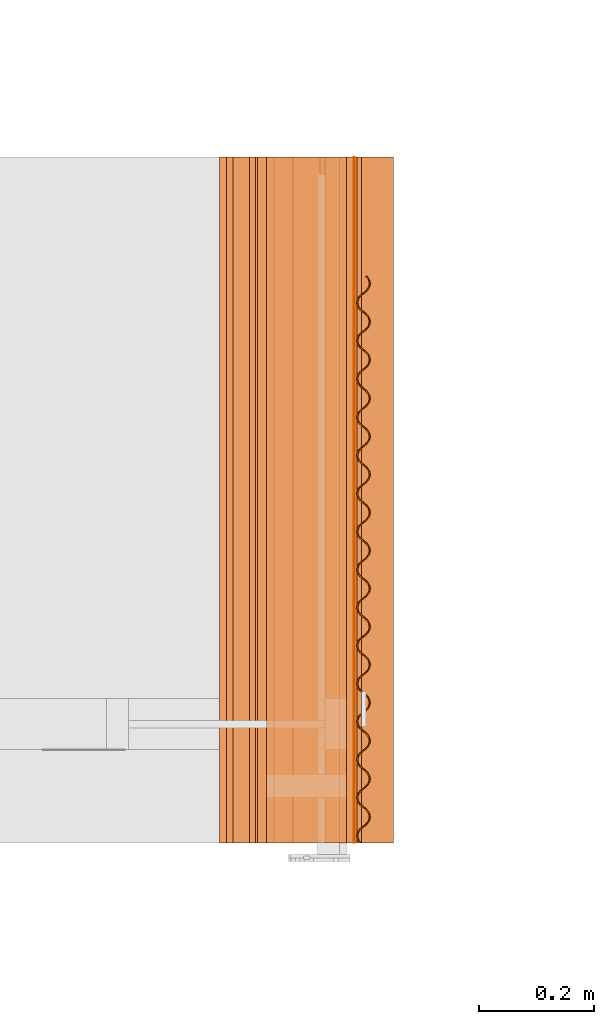
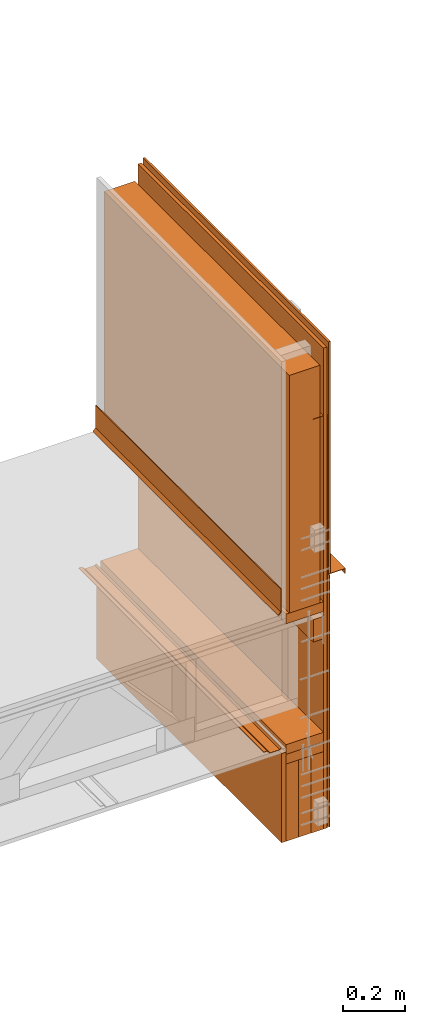
# One storey, part 2 of 22: 17 proxies.
"""IFC2X3 building model written with IfcOpenShell, lengths in feet."""

from ifc_helpers import new_model, entity, si_unit, converted_unit, frame, frame_2d, origin_with_axes, place, context, subcontext, project, spatial, polyline, rectangle, outline, extrude, shape, element, save


model = new_model("IFC2X3")

# Units and contexts
model_context = context("Model", 3, precision=1e-05)
plan_context = context("Plan", 2, precision=1e-05, world=frame_2d((0.0, 0.0, 0.0), x_axis=(1.0, 0.0, 0.0)))
body_context_1 = subcontext(model_context, "Body", "Model", "MODEL_VIEW")
body_context_2 = subcontext(model_context, "Body", "Model", "MODEL_VIEW")
ifc_project = project(units=[converted_unit("VOLUMEUNIT", "cubic foot", entity("IfcReal", 0.0283168467116885), si_unit("VOLUMEUNIT", "CUBIC_METRE"), dimensions=[3, 0, 0, 0, 0, 0, 0]), converted_unit("AREAUNIT", "square foot", entity("IfcReal", 0.09290304), si_unit("AREAUNIT", "SQUARE_METRE"), dimensions=[2, 0, 0, 0, 0, 0, 0]), converted_unit("LENGTHUNIT", "foot", entity("IfcReal", 0.3048), si_unit("LENGTHUNIT", "METRE"), dimensions=[1, 0, 0, 0, 0, 0, 0])], contexts=[model_context, plan_context])

# Site, building, storey
site_placement = place(None, origin_with_axes())
site = spatial("IfcSite", under=ifc_project, at=site_placement, CompositionType="ELEMENT")
building_placement = place(site_placement, origin_with_axes())
building = spatial("IfcBuilding", under=site, at=building_placement, Name="Building", CompositionType="ELEMENT")
storey_placement = place(building_placement, origin_with_axes())
storey = spatial("IfcBuildingStorey", under=building, at=storey_placement, Name="Storey", CompositionType="ELEMENT")

# Proxies
proxy_1_placement = place(storey_placement, frame((1595.46769510104, 0.875491228472842, -57.9246385829655), z_axis=(0.0, 0.0, 1.0), x_axis=(1.0, 0.0, 0.0)))
element("IfcBuildingElementProxy", 1, at=proxy_1_placement, inside=storey, Name="Plane", context=body_context_1, shape_type="SweptSolid", body=[
    extrude(rectangle(XDim=0.375023212116717, YDim=3.92583333372057, at=frame_2d((0.0, 0.0, 0.0))), frame((0.27084493339844, 2.97847343242075, -2.03039878465998), z_axis=(0.0, 0.0, -1.0), x_axis=(0.999999940395355, 0.0, 0.0)), (0.0, 0.0, -1.0), 3.07234290048816),
])
proxy_2_placement = place(storey_placement, frame((1595.45728227911, 1.8910506344217, -63.2148777718932), z_axis=(0.0, 0.0, 1.0), x_axis=(-1.62920684942947e-07, 1.0, 0.0)))
element("IfcBuildingElementProxy", 2, at=proxy_2_placement, inside=storey, Name="Generic Models 845:Generic Models 1", context=body_context_1, shape_type="SweptSolid", body=[
    extrude(rectangle(XDim=3.92583333372057, YDim=0.0520833335148361, at=frame_2d((0.0, 0.0, 0.0))), frame((1.96291666644139, -0.0260416674977682, 0.322346925109703), z_axis=(0.0, 0.0, -1.0), x_axis=(1.0, 0.0, 0.0)), (0.0, 0.0, -1.0), 1.15625032746861),
])
proxy_3_placement = place(storey_placement, frame((1593.45731960507, 1.8910506344217, -61.6841992055337), z_axis=(0.0, 0.0, 1.0), x_axis=(-1.62920684942947e-07, 1.0, 0.0)))
element("IfcBuildingElementProxy", 3, at=proxy_3_placement, inside=storey, Name="Dowel60:Dowel", context=body_context_1, shape_type="SweptSolid", body=[
    extrude(outline(polyline([(0.0667669798132629, 0.015256727502982), (0.106276372286278, 0.015256727502982), (0.106276372286278, 0.0204650634469518), (0.064609629735155, 0.0204650573359113), (0.0281512659052851, -0.0159932851053168), (-0.0894830373954272, -0.0159932973273978), (-0.108790796572768, 0.00331454740450999), (-0.112473651805888, -0.000368289853557101), (-0.0916403813624945, -0.0212016363268879), (0.0303086098723524, -0.0212016149382461), (0.0667669798132629, 0.015256727502982)])), frame((3.92583372398937, -1.88752637291205, 0.0212016454934487), z_axis=(1.0, -1.85782892003772e-06, 0.0), x_axis=(0.0, 0.999999940395355, -7.73365513850877e-08)), (-4.17659351548139e-10, -4.49406556413123e-09, -1.0), 3.92583333372057),
])
proxy_4_placement = place(storey_placement, frame((1595.50934638877, 1.8910506344217, -60.080036403626), z_axis=(0.0, 0.0, 1.0), x_axis=(-1.62920684942947e-07, 1.0, 0.0)))
element("IfcBuildingElementProxy", 4, at=proxy_4_placement, inside=storey, Name="Generic Models 857:Generic Models 1", context=body_context_1, shape_type="SweptSolid", body=[
    extrude(rectangle(XDim=0.458387200127976, YDim=3.92583333372057, at=frame_2d((0.0, 0.0, 0.0))), frame((1.96291666644139, -0.229193596780457, 0.0), z_axis=(0.0, 0.0, -1.0), x_axis=(-6.35700810364842e-15, 0.999999940395355, 0.0)), (-9.98035137064583e-14, -1.16558848618949e-14, -1.0), 0.125000000235113),
])
proxy_5_placement = place(storey_placement, frame((1595.2593385391, 0.875491228472842, -61.4761492711665), z_axis=(0.0, 0.0, 1.0), x_axis=(1.0, 0.0, 0.0)))
element("IfcBuildingElementProxy", 5, at=proxy_5_placement, inside=storey, Name="Plane", context=body_context_1, shape_type="SweptSolid", body=[
    extrude(rectangle(XDim=3.92583333372057, YDim=0.0416667373353818, at=frame_2d((0.0, 0.0, 0.0))), frame((0.729220980421452, 2.97847343242075, -1.41638314004332), z_axis=(0.0, 0.0, -1.0), x_axis=(0.0, -1.0, 0.0)), (0.0, 1.57243427167941e-08, -1.0), 6.21817093705122),
])
proxy_6_placement = place(storey_placement, frame((1595.96771080037, 1.8910506344217, -61.6425354023931), z_axis=(0.0, 0.0, 1.0), x_axis=(1.0, 0.0, 0.0)))
element("IfcBuildingElementProxy", 6, at=proxy_6_placement, inside=storey, Name="Generic Models 857:Generic Models 1", context=body_context_1, shape_type="SweptSolid", body=[
    extrude(rectangle(XDim=3.92583333372062, YDim=0.458337028879998, at=frame_2d((0.0, 0.0, 0.0))), frame((-0.22916851707018, 1.96291666644139, -0.124999744881169), z_axis=(2.39995301853924e-07, 1.5877549230936e-07, -1.0), x_axis=(0.0, -1.0, -1.5877549230936e-07)), (-3.26364776133056e-13, -1.95553198523157e-07, -1.0), 0.125000000235115),
])
proxy_7_placement = place(storey_placement, frame((1595.96771080037, 1.8910506344217, -61.7675330695205), z_axis=(0.0, 0.0, 1.0), x_axis=(1.0, 0.0, 0.0)))
element("IfcBuildingElementProxy", 7, at=proxy_7_placement, inside=storey, Name="Generic Models 857:Generic Models 1", context=body_context_1, shape_type="SweptSolid", body=[
    extrude(rectangle(XDim=3.92583333372062, YDim=0.458337028879998, at=frame_2d((0.0, 0.0, 0.0))), frame((-0.22916851707018, 1.96291666644139, -0.124999744881169), z_axis=(2.39995301853924e-07, 1.5877549230936e-07, -1.0), x_axis=(0.0, -1.0, -1.5877549230936e-07)), (-3.58418373105907e-13, -1.95553198523157e-07, -1.0), 0.125000025296795),
])
for number, where, z_axis, x_axis, name in (
    (8, (1595.83004127963, 1.891050829975, -62.7675331796561), (0.0, 0.0, 1.0), (1.0, 0.0, 0.0), "Generic Models 857:Generic Models 1"),
    (9, (1596.13591792389, 1.891050829975, -62.7675331796561), (0.0, 0.0, 1.0), (1.0, 0.0, 0.0), "Generic Models 857:Generic Models 1"),
    (10, (1595.98252904697, 1.891050829975, -62.7675331796561), (0.0, 0.0, 1.0), (1.0, 0.0, 0.0), "Generic Models 857:Generic Models 1"),
):
    element("IfcBuildingElementProxy", number, at=place(storey_placement, frame(where, z_axis=z_axis, x_axis=x_axis)), inside=storey, Name=name, context=body_context_1, shape_type="SweptSolid", body=[
        extrude(rectangle(XDim=3.92583333372062, YDim=0.152474618603812, at=frame_2d((0.0, 0.0, 0.0))), frame((-0.244431207420945, 1.96291666644139, -0.124999744881169), z_axis=(3.20632494776874e-07, 1.61888749516947e-07, -1.0), x_axis=(0.0, -1.0, -1.61888735306093e-07)), (5.39006101973882e-08, -2.80553450693333e-07, -1.0), 1.00000000188095),
    ])
proxy_8_placement = place(storey_placement, frame((1596.15273863625, 5.81679851051391, -59.6816208106013), z_axis=(0.0, 0.0, 1.0), x_axis=(1.0, 0.0, 0.0)))
element("IfcBuildingElementProxy", 11, at=proxy_8_placement, inside=storey, Name="Vert", shapes=[
    shape(model_context, None, "SweptSolid", [extrude(outline(polyline([(-0.111276951185831, -0.0128149069611012), (0.106073632406125, -0.0128149069611012), (0.105995484420008, -0.0752837169827439), (0.111236618318426, -0.0752902741292174), (0.111321329562057, -0.00757376236836194), (-0.106035853953656, -0.00757376236836194), (-0.106036562834355, 0.0956756847463255), (-0.111277696732774, 0.0956756480800824), (-0.111276951185831, -0.0128149069611012)])), frame((-0.026900244246083, -3.92574963607187, 0.0727010201516114), z_axis=(2.51794244832126e-06, -1.0, 2.70907967205858e-05), x_axis=(1.0, 1.7994273093791e-06, -6.80408447806258e-06)), (-5.10877271153731e-06, 3.48751855199225e-05, -1.0), 3.92582941395886)]),
])
proxy_9_placement = place(storey_placement, frame((1596.0439046224, 1.89104476782281, -59.6308019843314), z_axis=(3.25841057247089e-07, -8.02678641775856e-07, 1.0), x_axis=(1.0, -3.89414367418794e-07, -3.25841369885893e-07)))
element("IfcBuildingElementProxy", 12, at=proxy_9_placement, inside=storey, Name="Generic Models 1:Generic Models 1", context=body_context_2, shape_type="SweptSolid", body=[
    extrude(outline(polyline([(1.16708250887438, -2.11260580333082e-09), (1.15589578477104, 0.00647791606933856), (1.14346416838213, 0.00988080925882606), (1.1305774016956, 0.0101899866594046), (1.11800968021233, 0.0073867912643792), (1.10649990206315, 0.00145350277498413), (1.09679107199817, -0.00692655810880966), (1.06670949950306, -0.0407574166668447), (1.05699421617928, -0.0491374162492633), (1.04550585111608, -0.054971070525058), (1.03292356091221, -0.0578740714337882), (1.02003014541361, -0.0575647305628759), (1.00761974655737, -0.0540620165820823), (0.996406133875759, -0.0476837860972784), (0.987127912169679, -0.0388481015011942), (0.958679209700407, -0.00361300069286324), (0.94937673938556, 0.00522326292430987), (0.938190406388811, 0.0117010804531201), (0.925758789999904, 0.0151039682954472), (0.912865178947999, 0.0154134023597273), (0.900291786419125, 0.0126102459225853), (0.888800781386418, 0.00667651190014258), (0.879091560214836, -0.00170363854858878), (0.848997863415345, -0.035534108673611), (0.83927593127949, -0.0439139279803344), (0.827800277180559, -0.0497479000302359), (0.815211338164612, -0.0526507267743114), (0.802317922666004, -0.0523413859033991), (0.789902048317466, -0.0488386444229232), (0.778699973280348, -0.0424606033803753), (0.769410213929774, -0.0336246468429881), (0.740960875912288, 0.00161039285493765), (0.731671165450039, 0.0104463402257641), (0.720471877047396, 0.0169245725414493), (0.708046762805598, 0.0203272992050828), (0.695147285154798, 0.0206367668800858), (0.682579710336495, 0.0178336784282694), (0.67108269203992, 0.0118999887108705), (0.661373421980014, 0.00351994444146811), (0.631292289479824, -0.0303109259567079), (0.621570552897266, -0.0386907697075934), (0.610081992280765, -0.0445244270389083), (0.597499897630196, -0.0474274187810778), (0.584612739837076, -0.0471182306861784), (0.572196278828648, -0.0436154647615403), (0.560988532745932, -0.0372372862205809), (0.551698382288765, -0.0284013174611127), (0.52325569308336, 0.00683355647483914), (0.513953076103541, 0.0156698231475325), (0.502760045406387, 0.0221477965078759), (0.490335126717885, 0.0255506087260766), (0.477447968924765, 0.025859796820976), (0.46487433195427, 0.0230567450354027), (0.453377118104399, 0.0171231553862922), (0.44366804359779, 0.00874301677770189), (0.413580457838814, -0.0250876087969135), (0.403858916809553, -0.0334674525477989), (0.392376589454378, -0.0393012626551268), (0.379787845991728, -0.0422040832881618), (0.366894626046416, -0.041894760750371), (0.354484422743477, -0.0383921445462256), (0.343276505551626, -0.0320139660052662), (0.333986379538621, -0.0231780033568385), (0.305537432627728, 0.012057127242815), (0.296247379947209, 0.0208930043366755), (0.285048213765377, 0.0273711060288697), (0.272623099523579, 0.0307740358846003), (0.259729781801619, 0.0310832606457428), (0.247162304759964, 0.0282800652507174), (0.235658808760443, 0.0223466283776198), (0.225955943070997, 0.0139663339374963), (0.195874810570807, -0.0198644474686522), (0.186152951767438, -0.0282442728864161), (0.174658402331232, -0.0340777835527586), (0.162076026572799, -0.0369807752949281), (0.149188771003031, -0.0366715780334679), (0.136772493325819, -0.0331688212753907), (0.125570833839457, -0.0267906946782756), (0.116280903379748, -0.0179548359175367), (0.0878317486934774, 0.0172802014887489), (0.0785293028227926, 0.0261164635781619), (0.0673424564986404, 0.0325943926334616), (0.0549176233647064, 0.0359971024917336), (0.042024207866098, 0.0363064403071256), (0.0294504853410358, 0.0335033885215524), (0.0179470855904024, 0.0275699470651744), (0.00824273186259148, 0.0191896923468143), (-0.0218447484809348, -0.014640931700041), (-0.0315665033966146, -0.0230206685077174), (-0.0430486321429724, -0.0288545794472137), (-0.0556371739412856, -0.0317573175812018), (-0.0685307849931905, -0.0314479736547692), (-0.0809407010772253, -0.0279453696727049), (-0.0921424644512767, -0.0215673408522381), (-0.101432492687633, -0.0127313728566499), (-0.129887611749448, 0.0225037019797589), (-0.139183897691292, 0.0313398204597197), (-0.150370939568741, 0.0378177495150194), (-0.162801932631515, 0.041220609093784), (-0.175689188201284, 0.0415298063552442), (-0.188256653020858, 0.0387265987381378), (-0.199766308949219, 0.0327933039467322), (-0.209475542342882, 0.0244132631147901), (-0.239556577066424, -0.00941761224860633), (-0.249272080387656, -0.0177975957895436), (-0.260760469895022, -0.0236312500653383), (-0.273342955652184, -0.0265342479185482), (-0.286236371150793, -0.0262249039921157), (-0.298646281123787, -0.0227222098722037), (-0.309860358244478, -0.016343968693079), (-0.319137968846506, -0.00750830472175648), (-0.347587013534048, 0.0277268205307365), (-0.356889459404733, 0.0365630795646293), (-0.368076305728885, 0.0430409200098414), (-0.380507408790388, 0.0464437795886061), (-0.393400824288996, 0.0467532151806464), (-0.405974656812788, 0.0439500686739452), (-0.417465515180523, 0.0380163277765819), (-0.42717468746378, 0.0296361815291909), (-0.457268335374947, -0.00419429661657202), (-0.466990169734154, -0.0125741296731366), (-0.47846611716303, -0.0184080872093168), (-0.491054616184059, -0.0213109277032335), (-0.503948129459316, -0.0210015822490408), (-0.51636419936115, -0.0174988361852845), (-0.527565932179999, -0.0111208081286977), (-0.536856033748842, -0.00228483020266875), (-0.565305176213032, 0.0329501957454159), (-0.574595131116902, 0.0417861645048841), (-0.585794419519545, 0.0482643868901285), (-0.598219240431398, 0.0516670998039208), (-0.611118913635494, 0.0519765873398055), (-0.623686439565473, 0.0491734897214284), (-0.635183506750372, 0.043239794656869), (-0.644892727921954, 0.0348597522971668), (-0.674973860422144, 0.00102887072724478), (-0.684695548116379, -0.0073509637615949), (-0.696184108732879, -0.0131846126902291), (-0.708766398936745, -0.0160876074879188), (-0.721653507841541, -0.015778414809739), (-0.734069773296672, -0.0122756664543425), (-0.745277714932684, -0.00589748638562291), (-0.754567865389851, 0.00293848237384531), (-0.783010701260229, 0.038173366240238), (-0.792313073798427, 0.0470096313851712), (-0.803506104495582, 0.0534876032177545), (-0.815931023184083, 0.0568904200192355), (-0.828818132088879, 0.0571996020030944), (-0.841392013500995, 0.0543965654951224), (-0.852888982909245, 0.0484629620961708), (-0.862598301857475, 0.0400828250153406), (-0.89268564317483, 0.0062521910380445), (-0.902407477534036, -0.00212763743523968), (-0.913889682668401, -0.00796144448704724), (-0.926478328354402, -0.0108642849809639), (-0.939371743853011, -0.0105549425822915), (-0.951781556049357, -0.0070523500584281), (-0.962989595462018, -0.000674160154752697), (-0.972279648142537, 0.00816181099184072), (-1.00072854616511, 0.0433969308971733), (-1.01001869662227, 0.0522328049355135), (-1.02121793613659, 0.0587109295441097), (-1.03364290371342, 0.062113844122239), (-1.04653622143538, 0.0624230688833815), (-1.05910374736536, 0.0596198734883561), (-1.07060717003239, 0.0536864381430187), (-1.08031023127513, 0.0453061543972161), (-1.110391314887, 0.0114753691716672), (-1.12011305146956, 0.0030955355421926), (-1.1316077720149, -0.00273796519370911), (-1.14419006221876, -0.00564096667534938), (-1.15707722001188, -0.00533177437910962), (-1.16949348546701, -0.0018290239230429), (-1.18069526717419, 0.00454910744832257), (-1.18998522207806, 0.013384972320102), (-1.21843431565392, 0.0486200036153471), (-1.22773678596877, 0.0574562718158006), (-1.23892360784876, 0.0639341947600597), (-1.25134847764894, 0.0673369137848925), (-1.26424199092419, 0.0676462485447643), (-1.27681557900637, 0.0648431998147113), (-1.2883190016734, 0.0589097583583334), (-1.29802186736285, 0.05052946544597), (-1.29414365438652, 0.0470312430799555), (-1.285388146642, 0.0545328966979905), (-1.27504015062738, 0.0597929992661701), (-1.26372612132801, 0.0625261132485597), (-1.25211524212454, 0.0622475475776853), (-1.24093291797037, 0.0589747003858953), (-1.23084911445933, 0.0532244068137773), (-1.22248226889162, 0.0453119537746656), (-1.1940306331229, 0.01017701979531), (-1.18382392436501, 0.000417695969011356), (-1.17150064450236, -0.00668831461101888), (-1.1578403667515, -0.0105213738728579), (-1.14366441495775, -0.010861489943808), (-1.12983605914854, -0.00768793875771988), (-1.11719862291506, -0.00118077801753769), (-1.10651055971781, 0.0080772464131824), (-1.07643182274551, 0.041808020641289), (-1.06768257270648, 0.049309732314209), (-1.05733438113856, 0.0545698196047873), (-1.04602064516914, 0.0573029458092579), (-1.03440976596567, 0.0570243801383835), (-1.02321492640052, 0.0537512273945677), (-1.01313092733618, 0.0480009338224497), (-1.00478285488494, 0.0400890307769844), (-0.976325059187381, 0.00495394554937605), (-0.966111994947348, -0.00480563899873709), (-0.953788617308058, -0.011911651631695), (-0.940122179628357, -0.0157448483919456), (-0.925952583316743, -0.0160848101591227), (-0.91213058298967, -0.0129111084886619), (-0.899493048979541, -0.00640395185433504), (-0.888804985782293, 0.00285407572739032), (-0.858719991104496, 0.0365846026493261), (-0.849970741065468, 0.0440864120988943), (-0.839622745050846, 0.0493465085560334), (-0.828308813528126, 0.0520796317049837), (-0.816691676619172, 0.0518009132580964), (-0.805503094759513, 0.0485279102347732), (-0.795431757771124, 0.0427779161036406), (-0.787064863315092, 0.0348654630645288), (-0.758607116505856, -0.000269622998573363), (-0.748400261082987, -0.0100289607418119), (-0.736089301078025, -0.0171346777531849), (-0.72242281451, -0.0209677775006673), (-0.708247058269546, -0.0213079791261846), (-0.694418751348661, -0.0181344287039766), (-0.681774812968071, -0.011627428665063), (-0.671093105252959, -0.00236915645074696), (-0.641014466057299, 0.0313614352100243), (-0.632265167129947, 0.0388632354930317), (-0.621917220003649, 0.044123335005691), (-0.610590675293304, 0.0468561556581359), (-0.598992262612491, 0.0465779810938544), (-0.587797374159019, 0.0433047305733904), (-0.577713570647978, 0.037554537833441), (-0.569359191602922, 0.0296422925697068), (-0.54090149368201, -0.00549279189402154), (-0.530688380553654, -0.0152522786654864), (-0.518371162843204, -0.0223580529678642), (-0.504711129533963, -0.0261911863260695), (-0.4905288711464, -0.026531354340864), (-0.476713128524815, -0.0233575991987987), (-0.464069336809198, -0.0168505938127246), (-0.453381371388598, -0.00759257138718966), (-0.423302732192938, 0.0261381211057501), (-0.414553384377262, 0.0336399122221967), (-0.404199130657151, 0.0388998650698837), (-0.392885296911079, 0.0416329912743543), (-0.381280479859805, 0.0413545631018915), (-0.370085835847955, 0.0380814225801567), (-0.360008167821591, 0.0323313673386189), (-0.351641248921397, 0.0244188195783792), (-0.323189686485163, -0.0107161121093362), (-0.312976744465941, -0.0204755958252809), (-0.300665613351844, -0.0275813166560542), (-0.286999224560467, -0.0314144118202562), (-0.272823370543365, -0.031754619556814), (-0.258995161399128, -0.0285810645513256), (-0.246363860650325, -0.0220736680586585), (-0.235675773008915, -0.0128157357709712), (-0.205597060480769, 0.0209149475554078), (-0.19683536836325, 0.0284164483974299), (-0.186493642276197, 0.0336766945750616), (-0.175167317563311, 0.036409616059675), (-0.163568855994173, 0.0361313498297858), (-0.152379956360408, 0.0328582459742942), (-0.142289882921797, 0.0271077996261633), (-0.133929405058306, 0.019195600195233), (-0.105477757067505, -0.0159393414229233), (-0.0952712744181081, -0.0256987617368226), (-0.0829477073365622, -0.0328046704820917), (-0.0692874968071466, -0.0366378328677394), (-0.0551053850845558, -0.0369780894926214), (-0.0412896760736942, -0.0338041250474184), (-0.0286519342881879, -0.0272969882739732), (-0.0179575889412891, -0.0180392079984187), (0.0121209410195217, 0.0156915738684885), (0.020877929927483, 0.0231930869325917), (0.0312259106645043, 0.0284531910285315), (0.0425399216307508, 0.0311863172330021), (0.0541508955553448, 0.0309077362845263), (0.0653332380426368, 0.0276348890927364), (0.0754169621101514, 0.0218845985761386), (0.0837836915680899, 0.0139721485925472), (0.112235345669932, -0.0211627869145686), (0.122442127760314, -0.0309221186183804), (0.134765590954171, -0.0380281373623788), (0.148425709817979, -0.0418611805827364), (0.162601563835081, -0.0422012874871258), (0.176429882978048, -0.0390277385926779), (0.189067429210257, -0.0325205804305909), (0.199755516851668, -0.0232625648799765), (0.229834229379814, 0.0104682131675304), (0.238583503863004, 0.0179699240765703), (0.248931475433465, 0.023230015950429), (0.260245309179536, 0.0259631436826598), (0.271856383936299, 0.0256845719007448), (0.283051125724797, 0.0224114206846891), (0.293135149233297, 0.016661125584811), (0.301483197240379, 0.00874922712262612), (0.329940919605453, -0.0263858626882626), (0.340153959401323, -0.0361454388336951), (0.352477703703044, -0.0432514545221732), (0.36614419027107, -0.0470846657961451), (0.380313591029387, -0.0474246107579607), (0.394135640244784, -0.0442509060319797), (0.406773296475723, -0.0377437662030142), (0.417461164119675, -0.0284857323192784), (0.447546158797472, 0.0052447944116874), (0.456295311059852, 0.0127465901114144), (0.466643307074474, 0.018006692679594), (0.477957336373842, 0.0207398265228653), (0.489574571059445, 0.0204611050204577), (0.500763055142455, 0.0171881004693744), (0.51083434324252, 0.011438097935561), (0.519201384363525, 0.00352564909778966), (0.547658984507788, -0.0316094365117587), (0.557865986595629, -0.0413687651600503), (0.570176848823943, -0.0484744752965027), (0.583843286503644, -0.0523075796272655), (0.598019140520747, -0.0526477751417423), (0.611847496329956, -0.0494742415248957), (0.624491190268925, -0.0429672239167406), (0.635173191313981, -0.0337089730910664), (0.665251732732993, 2.16308992065482e-05), (0.674001276101966, 0.00752341274167179), (0.684349076563292, 0.0127835198931318), (0.69567542572034, 0.0155163504760175), (0.707273887289478, 0.0152381713284556), (0.718468824631273, 0.0119649223357517), (0.728552677030638, 0.00621473456102269), (0.736906958299046, -0.00169752540740275), (0.765364753996606, -0.0368326100621011), (0.775577622683342, -0.0465920884308853), (0.787894938170441, -0.0536978535667023), (0.801555118144654, -0.0575310098413094), (0.815737229867244, -0.0578711686895432), (0.829552825823856, -0.0546973997976367), (0.842196910869418, -0.0481904188557247), (0.852884680736722, -0.0389323819164685), (0.882963808815623, -0.00520171539545098), (0.891712765524706, 0.00230010990462855), (0.902067019244817, 0.00756005377672476), (0.913380755214241, 0.0102931807450755), (0.924985474488867, 0.0100147541003727), (0.936180705160606, 0.00674159600939651), (0.946258055412863, 0.00099157523794657), (0.954624900980571, -0.00692097949269875), (0.983076438972643, -0.0420559119442942), (0.993289796542621, -0.051815420868281), (1.00560065877093, -0.0589211248936928), (1.01926738978058, -0.0627542445020569), (1.03344265713779, -0.0630944277944527), (1.04727111072365, -0.0599208789000048), (1.05990268035824, -0.0534134946294188), (1.07059045022554, -0.0441555585223311), (1.10066918719785, -0.0104248583905907), (1.1094308548712, -0.00292335162849808), (1.11977259318034, 0.0023368964588338), (1.13109904011403, 0.00506980553039611), (1.14269769723647, 0.00479151027306445), (1.15388667020272, 0.0015184226500242), (1.16397653586595, -0.00423202427101671), (1.17233692817488, -0.0121442149173263), (1.20078866172025, -0.0472791588271227), (1.21099517492485, -0.0570385944186233), (1.22331874811743, -0.0641445123304532), (1.236978830315, -0.0679776502719388), (1.25116113759088, -0.0683179130078614), (1.26497688021247, -0.0651439730068204), (1.27761470755254, -0.058636820955774), (1.28830893067863, -0.0493790223470979), (1.31838727654435, -0.0156482481189913), (1.31450916134466, -0.0121501258212653), (1.28442152669736, -0.045980755215281), (1.27469959456151, -0.0543604675787953), (1.26321748720379, -0.0601943846293322), (1.25062913484774, -0.0630971472074823), (1.23773571934913, -0.0627878002255295), (1.22532571159949, -0.0592851962434651), (1.21412363656237, -0.0529071582564375), (1.20483387721179, -0.0440711833859288), (1.17637852593044, -0.00883610702175989), (1.16708250887438, -2.11260580333082e-09)]), holes=[polyline([(1.58285111032446, -0.000660819419109069), (1.59527588234799, -0.0040637414928115), (1.60647512186231, -0.0105418550251467), (1.61576527231947, -0.0193777305912471), (1.64421407256539, -0.0546128596631404), (1.65350422302256, -0.0634488314781289), (1.66471216465857, -0.0698270100190884), (1.67712197685492, -0.0733296140011527), (1.69001519680023, -0.0736389609831055), (1.70260374470959, -0.0707361189614287), (1.71408643872719, -0.0649023119096211), (1.72380797975645, -0.0565224742697762), (1.75389522329716, -0.0226918364730798), (1.76360444446874, -0.0143117070310502), (1.77510180498358, -0.00837811509029954), (1.7876754908424, -0.00557506292278627), (1.80056245308223, -0.00588424032336477), (1.81298810509559, -0.00928706209006624), (1.82418059802118, -0.0157650270477289), (1.83348287278273, -0.024601313581304), (1.8619259042064, -0.0598361859894956), (1.87121625021687, -0.0686721639155246), (1.88242380074629, -0.075050318012322), (1.89484026175471, -0.0785530869924803), (1.90772761510113, -0.0788622689763392), (1.9203095141984, -0.075959268067609), (1.9317984659215, -0.0701256382359764), (1.94152020250406, -0.0617458005961314), (1.94540095767324, -0.0651438507860101), (1.93471905440483, -0.0744020832785628), (1.92207516491257, -0.0809090886646368), (1.90824680910336, -0.0840826192259632), (1.89407095508625, -0.0837424237114864), (1.88040471295985, -0.0799093285472844), (1.86809365517824, -0.0728036122997915), (1.85788655531375, -0.0630442989291012), (1.82942866183954, -0.0279091862018105), (1.82106171849519, -0.019996736218219), (1.81099052817177, -0.0142467512536471), (1.79980194631211, -0.0109737657995655), (1.7881849071798, -0.010695022144636), (1.77687078010379, -0.0134281437658262), (1.76652268631252, -0.0186882463340058), (1.75777382738008, -0.0261900618946145), (1.72768873492564, -0.0599206039031816), (1.71700057395174, -0.0691785980651541), (1.70436313771826, -0.0756857623382816), (1.69054084406124, -0.0788594701197829), (1.67637183440952, -0.0785195251579673), (1.66270520117652, -0.0746863138839954), (1.65038182353723, -0.0675802981955173), (1.64016895485049, -0.0578207220500848), (1.61171115915293, -0.0226856505723176), (1.60336289114839, -0.0147737291937308), (1.59327928319065, -0.00902344326041346), (1.58208424807221, -0.00575028478749722), (1.57047327109209, -0.00547171529722241), (1.55915933956937, -0.00820483042543211), (1.54881153910805, -0.0134649475073329), (1.54006238684567, -0.0209666576524928), (1.50998325876676, -0.0546974181307582), (1.49929509779287, -0.0639554367368928), (1.48665766155939, -0.0704625887879393), (1.47282940352683, -0.0736361499044682), (1.45865315840313, -0.0732960338335181), (1.44499288065227, -0.0694629753355592), (1.43266989411957, -0.0623569779802026), (1.42246298980838, -0.0525976279432692), (1.3940116473696, -0.0174627291023966), (1.3856444106953, -0.00955025085524272), (1.37556080273756, -0.00379995231790434), (1.36437847858339, -0.000527103789324268), (1.35276769715657, -0.00024854652113049), (1.34145337452726, -0.00298164980919919), (1.33110557406593, -0.00824176020714946), (1.32235016409806, -0.015743419936225), (1.31847204889838, -0.0122452052090112), (1.32817501236448, -0.00386491191470776), (1.33967814170157, 0.0020685423366613), (1.35225172978374, 0.00487159851454492), (1.36514534083564, 0.00456226375467313), (1.37757011285917, 0.00115953117096919), (1.38875703251581, -0.00531838241575916), (1.39805950283066, -0.0141546532897929), (1.42650820529993, -0.0493896708351968), (1.43579855131039, -0.0582255540400978), (1.44700023524092, -0.0646036836927331), (1.45941669624934, -0.0681064404508104), (1.47230385404246, -0.0684156346567503), (1.48488575313974, -0.0655126337480201), (1.49638057146173, -0.0596791261371978), (1.50610230804428, -0.0512992884973528), (1.53618388053939, -0.0174685300076063), (1.54588684400548, -0.00908821799824127), (1.55738997334258, -0.00315476871209263), (1.56995769482585, -0.000351587019165919), (1.58285111032446, -0.000660819419109069)])]), frame((0.0194650527769382, 1.29889452394851, -3.26173512015756), z_axis=(5.88078764849342e-05, -4.55611461802619e-06, 1.0), x_axis=(-0.0239849984645844, 0.999712288379669, -5.69695157537353e-06)), (-5.9536934713833e-05, 9.96606104308739e-05, 0.999999940395355), 3.26176209987388),
])
proxy_10_placement = place(storey_placement, frame((1596.02708391004, 5.81688142511163, -59.6164906118798), z_axis=(0.0, 0.0, 1.0), x_axis=(1.0, 0.0, 0.0)))
element("IfcBuildingElementProxy", 13, at=proxy_10_placement, inside=storey, Name="Plane", context=body_context_1, shape_type="SweptSolid", body=[
    extrude(rectangle(XDim=3.92583333372057, YDim=0.0259999838903791, at=frame_2d((0.0, 0.0, 0.0))), frame((0.0130391027045062, -1.96291666644139, -1.5644263720575e-06), z_axis=(0.0, 0.0, -1.0), x_axis=(0.0, -1.0, 0.0)), (0.0, 0.0, -0.999999940395355), 2.99999996554402),
])
proxy_11_placement = place(storey_placement, frame((1595.45728227911, 1.93270113993817, -60.0175156680931), z_axis=(0.0, 0.0, 1.0), x_axis=(1.0, 0.0, 0.0)))
element("IfcBuildingElementProxy", 14, at=proxy_11_placement, inside=storey, Name="Vert", context=body_context_2, shape_type="SweptSolid", body=[
    extrude(outline(polyline([(0.207891805082794, -7.65745006044874e-10), (0.208232018930393, 0.0104439370590812), (-0.0874580524548927, 0.0200758787761797), (-0.126168982485148, -0.0161926471078255), (-0.119024552795987, -0.0238181837391978), (-0.0834722423881996, 0.0094910249422033), (0.207891805082794, -7.65745006044874e-10)])), frame((-0.0171850373103159, 3.88417969851356, 0.198466502853579), z_axis=(-8.71472252583771e-07, 1.0, -2.78422498922737e-06), x_axis=(0.0325571373105049, 1.88129877187748e-06, 0.999469816684723)), (-8.03013961103716e-07, 2.29300667342613e-07, -1.0), 3.92582973837173),
])
proxy_12_placement = place(storey_placement, frame((1595.91774927975, 2.57071606286867, -60.258937945829), z_axis=(0.0, 0.0, 1.0), x_axis=(1.0, 0.0, 0.0)))
element("IfcBuildingElementProxy", 15, at=proxy_12_placement, inside=storey, Name="Generic Models 855:Generic Models 1", context=body_context_1, shape_type="SweptSolid", body=[
    extrude(rectangle(XDim=0.124999233345449, YDim=3.92583562166899, at=frame_2d((0.0, 0.0, 0.0))), frame((-0.0125009400325184, 1.28324996689799, -0.174600005228063), z_axis=(-1.56443593368749e-06, 0.0, -1.0), x_axis=(0.999999940395355, 0.0, -1.56443593368749e-06)), (1.12248699224438e-06, 0.0, -0.999999940395355), 0.291000029617698),
])
proxy_13_placement = place(storey_placement, frame((1596.0093620881, 1.89101817257448, -60.7665692727397), z_axis=(0.0, 0.0, 1.0), x_axis=(1.0, 0.0, 0.0)))
element("IfcBuildingElementProxy", 16, at=proxy_13_placement, inside=storey, Name="Vert", context=body_context_2, shape_type="SweptSolid", body=[
    extrude(outline(polyline([(-1.96293152849192, -0.00262057153248959), (1.96293152849192, -0.00262057153248959), (1.96293152849192, 0.00262057172345961), (-1.96293152849192, 0.00262057172345961), (-1.96293152849192, -0.00262057153248959)])), frame((0.00258776135595999, 1.96293152849192, -2.12596294291689), z_axis=(0.0, 0.0, -1.0), x_axis=(0.0, -1.0, 0.0)), (0.0, 0.0, -1.0), 3.37931668959284),
])
proxy_14_placement = place(storey_placement, frame((1596.0282853895, 1.8911012827255, -59.5208853874307), z_axis=(-2.2670858856118e-14, 1.0, -1.62920684942947e-07), x_axis=(1.0, 2.2670858856118e-14, 1.82812812841114e-15)))
element("IfcBuildingElementProxy", 17, at=proxy_14_placement, inside=storey, Name="Vert", context=body_context_2, shape_type="SweptSolid", body=[
    extrude(outline(polyline([(-1.18620498130328, 0.0262368816315267), (0.754001249713222, 0.0262368816315267), (0.774834569044939, 0.0387368775082855), (0.851687405678857, 0.0387368683417247), (0.851687405678857, 0.0439780052956634), (0.771929722601973, 0.0439780266843052), (0.751096403270256, 0.0314780277520262), (-1.19141334780245, 0.0314780216409857), (-1.19141334780245, -0.140429792187502), (-1.18620498130328, -0.140429792187502), (-1.18620498130328, 0.0262368816315267)])), frame((-0.0451547044801118, -0.782505733760323, -3.04033336739283e-05), z_axis=(4.47603724751389e-07, -1.87735338386119e-07, -1.0), x_axis=(-1.57484301155364e-08, 1.0, -1.87741591162194e-07)), (-1.43285831200046e-06, 1.05777110093186e-06, -1.0), 3.9258294115264),
])

save(model, "model.ifc")
